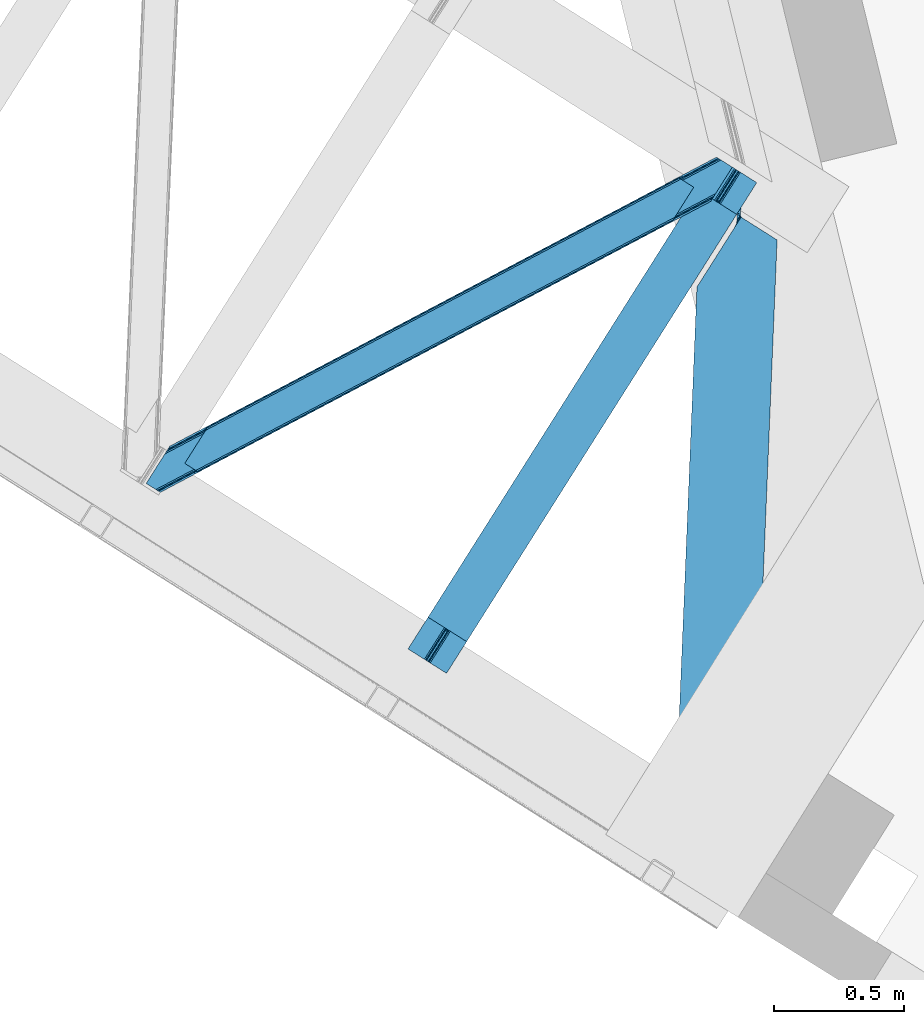
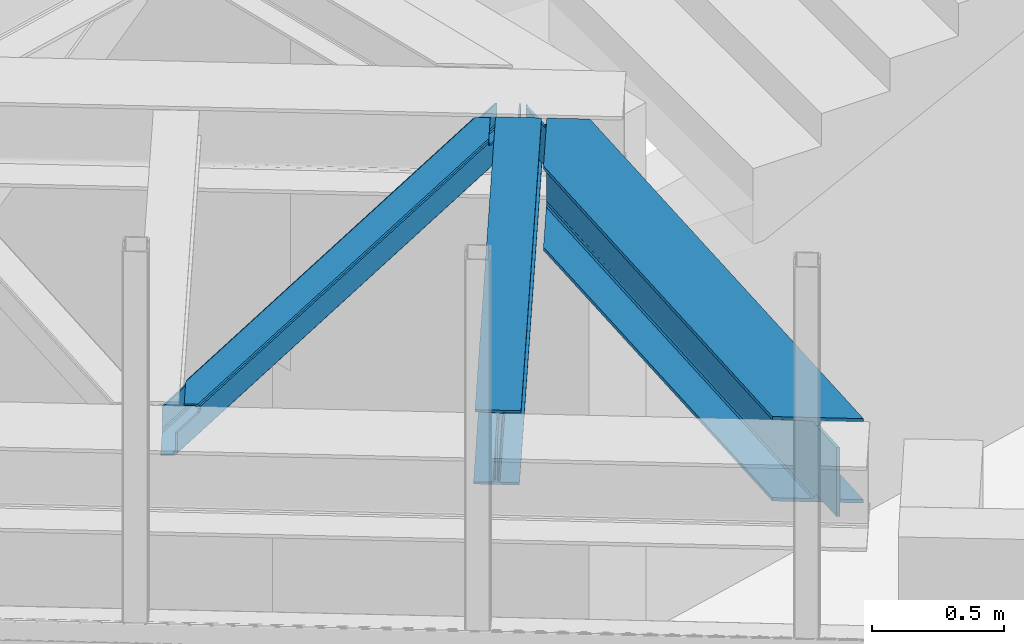
# One storey, part 50 of 67: 2 beams, 1 member.
"""IFC4 building model written with IfcOpenShell, lengths in millimetres."""

from ifc_helpers import new_model, entity, si_unit, converted_unit, derived_unit, direction, frame, origin, place, context, subcontext, project, spatial, triangles, type_object, element, save


model = new_model("IFC4")

# Units and contexts
model_context = context("Model", 3, precision=0.01, world=origin(), true_north=direction((6.12303176911189e-17, 1.0)))
plan_context = context("Plan", 3, precision=0.01, world=origin(), true_north=direction((6.12303176911189e-17, 1.0)))
body_context = subcontext(model_context, "Body", "Model", "MODEL_VIEW")
ifc_project = project(units=[si_unit("LENGTHUNIT", "METRE", prefix="MILLI"), si_unit("AREAUNIT", "SQUARE_METRE"), si_unit("VOLUMEUNIT", "CUBIC_METRE"), converted_unit("PLANEANGLEUNIT", "DEGREE", entity("IfcRatioMeasure", 0.0174532925199433), si_unit("PLANEANGLEUNIT", "RADIAN"), dimensions=[0, 0, 0, 0, 0, 0, 0]), si_unit("MASSUNIT", "GRAM", prefix="KILO"), derived_unit("MASSDENSITYUNIT", [(si_unit("MASSUNIT", "GRAM", prefix="KILO"), 1), (si_unit("LENGTHUNIT", "METRE"), -3)]), derived_unit("MOMENTOFINERTIAUNIT", [(si_unit("LENGTHUNIT", "METRE"), 4)]), si_unit("TIMEUNIT", "SECOND"), si_unit("FREQUENCYUNIT", "HERTZ"), si_unit("THERMODYNAMICTEMPERATUREUNIT", "DEGREE_CELSIUS"), derived_unit("THERMALTRANSMITTANCEUNIT", [(si_unit("MASSUNIT", "GRAM", prefix="KILO"), 1), (si_unit("THERMODYNAMICTEMPERATUREUNIT", "KELVIN"), -1), (si_unit("TIMEUNIT", "SECOND"), -3)]), derived_unit("VOLUMETRICFLOWRATEUNIT", [(si_unit("LENGTHUNIT", "METRE"), 3), (si_unit("TIMEUNIT", "SECOND"), -1)]), derived_unit("MASSFLOWRATEUNIT", [(si_unit("MASSUNIT", "GRAM", prefix="KILO"), 1), (si_unit("TIMEUNIT", "SECOND"), -1)]), derived_unit("ROTATIONALFREQUENCYUNIT", [(si_unit("TIMEUNIT", "SECOND"), -1)]), si_unit("ELECTRICCURRENTUNIT", "AMPERE"), si_unit("ELECTRICVOLTAGEUNIT", "VOLT"), si_unit("POWERUNIT", "WATT"), si_unit("FORCEUNIT", "NEWTON", prefix="KILO"), si_unit("ILLUMINANCEUNIT", "LUX"), si_unit("LUMINOUSFLUXUNIT", "LUMEN"), si_unit("LUMINOUSINTENSITYUNIT", "CANDELA"), derived_unit("USERDEFINED", [(si_unit("MASSUNIT", "GRAM", prefix="KILO"), -1), (si_unit("LENGTHUNIT", "METRE"), -2), (si_unit("TIMEUNIT", "SECOND"), 3), (si_unit("LUMINOUSFLUXUNIT", "LUMEN"), 1)]), derived_unit("LINEARVELOCITYUNIT", [(si_unit("LENGTHUNIT", "METRE"), 1), (si_unit("TIMEUNIT", "SECOND"), -1)]), si_unit("PRESSUREUNIT", "PASCAL"), derived_unit("USERDEFINED", [(si_unit("LENGTHUNIT", "METRE"), -2), (si_unit("MASSUNIT", "GRAM", prefix="KILO"), 1), (si_unit("TIMEUNIT", "SECOND"), -2)]), derived_unit("LINEARFORCEUNIT", [(si_unit("MASSUNIT", "GRAM", prefix="KILO"), 1), (si_unit("LENGTHUNIT", "METRE"), 1), (si_unit("TIMEUNIT", "SECOND"), -2), (si_unit("LENGTHUNIT", "METRE"), -1)]), derived_unit("PLANARFORCEUNIT", [(si_unit("MASSUNIT", "GRAM", prefix="KILO"), 1), (si_unit("LENGTHUNIT", "METRE"), 1), (si_unit("TIMEUNIT", "SECOND"), -2), (si_unit("LENGTHUNIT", "METRE"), -2)])], contexts=[model_context, plan_context])

# Site, building, storey
site_placement = place(None, origin())
site = spatial("IfcSite", under=ifc_project, at=site_placement, CompositionType="ELEMENT")
building_placement = place(site_placement, origin())
building = spatial("IfcBuilding", under=site, at=building_placement, CompositionType="ELEMENT")
storey_placement = place(building_placement, frame((0.0, 0.0, 19800.0)))
storey = spatial("IfcBuildingStorey", under=building, at=storey_placement, CompositionType="ELEMENT", Elevation=19800.0)

# Beams
beam_type_1 = type_object("IfcBeamType", PredefinedType="BEAM")
beam_1_placement = place(storey_placement, frame((-1267.76636695862, 13575.9713378906, 3863.99976196289)))
element("IfcBeam", 1, at=beam_1_placement, inside=storey, type_object=beam_type_1, ObjectType="Steel Beam", PredefinedType="BEAM", context=body_context, shape_type="Tessellation", body=[
    triangles([(1113.74242901802, 1855.23675842285, 232.99973144531), (1171.22194197178, 1818.90060424805, 232.99973144531), (134.557775115967, 179.105346679688, 232.99973144531), (77.078289413452, 215.441500854493, 232.99973144531), (1113.74242901802, 1855.23675842285, 244.001385498046), (77.078289413452, 215.441500854493, 244.001385498046), (1261.66156323999, 1761.72269897461, 244.001385498046), (225.001891136169, 121.928604125977, 244.001385498046), (1261.66156323999, 1761.72269897461, 232.99973144531), (225.001891136169, 121.928604125977, 232.99973144531), (1204.18659954071, 1798.06001586914, 232.99973144531), (167.522478103638, 158.264758300782, 232.99973144531), (1199.00899951458, 1801.33190917969, 231.783526611329), (1176.39499104023, 1815.62754821777, 231.783526611329), (1191.69133661985, 1805.95953369141, 223.123590087889), (1180.78569324017, 1812.85446166992, 228.313970947263), (1194.62281647921, 1804.10615844727, 228.313970947263), (1190.76869580746, 1806.54321899414, 219.000585937498), (1184.63980937004, 1810.41740112305, 219.000585937498), (1183.71717309952, 1811.00108642578, 223.123590087889), (157.958672332764, 164.310900878907, 228.313970947263), (162.344887161255, 161.536651611328, 231.783526611329), (144.121508216858, 173.06036682129, 228.313970947263), (139.730860519409, 175.832290649414, 231.783526611329), (154.104547119141, 166.747961425781, 219.000585937498), (155.027165222168, 166.164276123047, 223.123590087889), (147.975706100464, 170.622143554687, 219.000585937498), (147.053015327454, 171.206991577148, 223.123590087889), (147.982028388977, 170.400064086914, 217.00070800781), (1184.84340341091, 1810.50576782227, 217.00070800781), (1190.76235535145, 1806.76529846191, 217.00070800781), (153.900925827026, 166.659594726563, 217.00070800781), (1191.11113493443, 1807.31759033203, 214.791540527342), (1185.19218299389, 1811.05805969238, 214.791540527342), (1192.38168329, 1809.33258361816, 211.221990966795), (1186.46725051403, 1813.07421569824, 211.221990966795), (1194.28882523775, 1812.34867858887, 208.838415527342), (1188.37442879677, 1816.09031066895, 208.838415527342), (1196.54243041277, 1815.90776367188, 208.001257324217), (1190.62348301411, 1819.64823303223, 208.001257324217), (153.55218257904, 166.107302856446, 214.791540527342), (147.633212471008, 169.847772216797, 214.791540527342), (152.277042388916, 164.092309570313, 211.221990966795), (146.358217620849, 167.831616210937, 211.221990966795), (150.369964027405, 161.075051879883, 208.838415527342), (144.450993919372, 164.815521240234, 208.838415527342), (148.120828056335, 157.517129516602, 208.001257324217), (142.201930618286, 161.257598876953, 208.001257324217), (1267.74426928712, 1928.53809814453, 208.001257324217), (1261.82531823367, 1932.27856750488, 208.001257324217), (76.9144912719726, 44.8867950439453, 208.001257324217), (71.0000993728638, 48.6272644042965, 208.001257324217), (1261.82531823367, 1932.27856750488, 27.0006774902322), (71.0000993728638, 48.6272644042965, 27.0006774902322), (1267.74426928712, 1928.53809814453, 27.0006774902322), (76.9144912719726, 44.8867950439453, 27.0006774902322), (1253.4777905345, 1937.55615234375, 12.2178588867173), (1248.30474373698, 1940.82920837402, 10.9993286132813), (57.4749801635742, 57.1767425537109, 10.9993286132813), (62.6525711059569, 53.9060119628903, 12.2178588867173), (1257.86397470534, 1934.78190307617, 15.6874145507791), (67.0387859344482, 51.1317626953132, 15.6874145507791), (1260.8000060901, 1932.92969055176, 20.877795410157), (69.970220375061, 49.2783874511715, 20.877795410157), (1190.82522397041, 1977.16536254883, 10.9993286132813), (0.0, 93.5140594482418, 10.9993286132813), (1190.82522397041, 1977.16536254883, 0.0), (0.0, 93.5140594482418, 0.0), (1338.74436103106, 1883.65130310059, 0.0), (147.91916885376, 0.0, 0.0), (85.2665977478027, 39.6092102050789, 12.2178588867173), (80.8758047103881, 42.3822967529304, 15.6874145507791), (77.9443702697754, 44.2356719970703, 20.877795410157), (90.4396104812622, 36.3373168945309, 10.9993286132813), (147.91916885376, 0.0, 10.9993286132813), (1271.70561341867, 1926.03359985352, 15.6874145507791), (1276.09179787338, 1923.25935058594, 12.2178588867173), (1281.26939676404, 1919.98861999512, 10.9993286132813), (1338.74436103106, 1883.65130310059, 10.9993286132813), (1268.77413476575, 1927.88697509766, 20.877795410157)], [[1, 2, 3], [3, 4, 1], [5, 1, 4], [4, 6, 5], [7, 5, 8], [6, 8, 5], [9, 7, 10], [8, 10, 7], [11, 9, 10], [10, 12, 11], [11, 13, 14], [15, 16, 17], [13, 17, 16], [15, 18, 19], [7, 11, 5], [11, 7, 9], [2, 11, 14], [16, 15, 20], [19, 20, 15], [16, 14, 13], [2, 5, 11], [5, 2, 1], [21, 22, 23], [12, 8, 6], [10, 8, 12], [22, 12, 24], [25, 26, 27], [26, 21, 23], [23, 22, 24], [6, 3, 12], [3, 24, 12], [6, 4, 3], [23, 28, 26], [28, 27, 26], [19, 29, 27], [27, 20, 19], [19, 30, 29], [27, 28, 20], [16, 20, 23], [28, 23, 20], [14, 16, 23], [23, 24, 14], [2, 14, 3], [24, 3, 14], [25, 31, 18], [18, 26, 25], [18, 15, 26], [25, 32, 31], [15, 17, 26], [21, 26, 17], [17, 13, 22], [22, 21, 17], [13, 11, 12], [12, 22, 13], [31, 33, 34], [34, 30, 31], [18, 31, 30], [30, 19, 18], [33, 35, 34], [36, 34, 35], [35, 37, 38], [38, 36, 35], [37, 39, 38], [40, 38, 39], [41, 32, 42], [29, 42, 32], [32, 25, 27], [27, 29, 32], [43, 41, 42], [42, 44, 43], [45, 43, 46], [44, 46, 43], [47, 45, 46], [46, 48, 47], [49, 50, 39], [40, 39, 50], [47, 48, 51], [52, 51, 48], [36, 53, 54], [38, 53, 36], [50, 53, 40], [38, 40, 53], [30, 34, 42], [34, 36, 42], [44, 36, 54], [54, 46, 44], [48, 46, 54], [54, 52, 48], [44, 42, 36], [42, 29, 30], [55, 35, 56], [33, 41, 35], [37, 35, 55], [33, 31, 32], [55, 39, 37], [39, 55, 49], [56, 35, 43], [43, 35, 41], [32, 41, 33], [43, 45, 56], [47, 56, 45], [56, 47, 51], [57, 58, 59], [59, 60, 57], [61, 57, 62], [60, 62, 57], [63, 61, 62], [62, 64, 63], [53, 63, 54], [64, 54, 63], [58, 65, 66], [66, 59, 58], [65, 67, 66], [68, 66, 67], [67, 69, 68], [70, 68, 69], [71, 72, 60], [56, 64, 73], [72, 73, 62], [56, 51, 54], [74, 68, 70], [70, 75, 74], [74, 71, 59], [60, 72, 62], [64, 56, 54], [52, 54, 51], [64, 62, 73], [68, 74, 59], [60, 59, 71], [66, 68, 59], [76, 77, 57], [78, 69, 67], [79, 69, 78], [77, 78, 58], [55, 80, 63], [80, 76, 61], [49, 55, 53], [61, 76, 57], [67, 58, 78], [58, 57, 77], [67, 65, 58], [63, 53, 55], [53, 50, 49], [61, 63, 80], [80, 55, 73], [56, 73, 55], [76, 80, 73], [73, 72, 76], [77, 76, 71], [72, 71, 76], [78, 77, 71], [71, 74, 78], [79, 78, 75], [74, 75, 78], [69, 79, 70], [75, 70, 79]]),
])
beam_type_2 = type_object("IfcBeamType", PredefinedType="BEAM")
beam_2_placement = place(storey_placement, frame((-235.751834535599, 12925.2843109131, 3715.9994934082)))
element("IfcBeam", 2, at=beam_2_placement, inside=storey, type_object=beam_type_2, ObjectType="Steel Beam", PredefinedType="BEAM", context=body_context, shape_type="Tessellation", body=[
    triangles([(233.281526336074, 2423.1276763916, 356.001525878906), (244.678622616827, 2415.92462768555, 356.001525878906), (238.341486717761, 2545.92599487305, 356.001525878906), (250.747194671631, 2565.55502929687, 356.001525878906), (245.781376549602, 2403.50561828613, 362.41043701172), (244.023252917826, 2403.74630126953, 364.221954345703), (245.537573298812, 2402.36499023438, 367.000854492188), (242.53565749079, 2405.33225097656, 362.817388916017), (244.82996353358, 2406.62286987305, 359.222259521484), (241.500046648085, 2406.43916015625, 361.83837890625), (238.207450908422, 2409.10643920898, 361.001220703125), (232.385556542873, 2414.48983154297, 359.222259521484), (231.81794237718, 2413.14689025879, 361.001220703125), (244.56884098202, 2411.01329956055, 356.838684082031), (232.990733709186, 2418.33145751953, 356.838684082031), (248.213948589563, 2400.67439575195, 367.000854492188), (231.194143527746, 2398.01176757813, 361.001220703125), (245.848223850131, 2402.17081604004, 367.79150390625), (229.080534236133, 2380.1116973877, 364.221954345703), (226.37978554666, 2371.37618408203, 367.79150390625), (246.55568203032, 2401.72316894531, 372.000549316406), (224.501758146286, 2367.80779724121, 369.407684326172), (221.500491258502, 2362.09186706543, 372.000549316406), (230.523896920681, 2389.07626647949, 361.83837890625), (230.180002690852, 2386.93221130371, 362.408111572266), (265.525510007143, 2389.72971496582, 376.000305175781), (257.313895046711, 2394.92125854492, 374.325988769531), (246.55568203032, 2401.72316894531, 392.001654052736), (250.749615490437, 2399.07100524902, 369.042590332032), (384.774951267242, 2314.34245605469, 392.001654052736), (384.774951267242, 2314.34245605469, 376.000305175781), (292.630248641968, 77.4278320312496, 392.001654052736), (292.630248641968, 77.4278320312496, 376.000305175781), (173.385328817368, 152.816253662109, 376.000305175781), (77.0741108894348, 2133.64185791016, 392.001654052736), (0.0, 262.429330444336, 392.001654052736), (216.970907637477, 2354.92835083008, 374.325988769531), (207.956919550896, 2340.67108154297, 376.000305175781), (77.0741108894348, 2133.64185791016, 376.000305175781), (119.244928908348, 187.040908813477, 376.000305175781), (0.0, 262.429330444336, 376.000305175781), (158.208139300346, 162.40869140625, 369.556512451174), (165.173679792881, 158.008959960938, 374.325988769531), (134.422118425369, 177.448471069336, 369.556512451174), (127.461097097397, 181.849365234375, 374.325988769531), (152.011397266388, 166.325894165038, 356.001525878906), (153.556270265579, 165.350372314453, 362.419738769531), (140.61885137558, 173.531268310548, 356.001525878906), (139.073923873901, 174.50795288086, 362.419738769531), (133.766217327118, 7.20304870605469, 356.001525878906), (145.163350510597, 0.0, 356.001525878906), (133.856409859657, 7.14723815917932, 354.001647949219), (238.437992171198, 2546.08063659668, 354.001647949219), (250.747194671631, 2565.55502929687, 354.001647949219), (145.07314889431, 0.0558105468753638, 354.001647949219), (250.747194671631, 2565.55502929687, 179.000701904297), (238.437992171198, 2546.08063659668, 179.000701904297), (244.730604931712, 2419.42325134277, 179.000701904297), (232.416850054264, 2399.94769592285, 179.000701904297), (244.381695905328, 2410.99585876465, 178.163543701172), (232.072493688762, 2391.52146606445, 178.163543701172), (244.088522484899, 2403.85210876465, 175.777642822268), (231.77476760745, 2384.37655334473, 175.777642822268), (243.892482148111, 2399.07914428711, 172.210418701172), (231.578761618584, 2379.60358886719, 172.210418701172), (243.822449858487, 2397.40250244141, 168.001373291016), (231.508694413304, 2377.92694702148, 168.001373291016), (133.856409859657, 7.14723815917932, 38.0000061035171), (231.508694413304, 2377.92694702148, 38.0000061035171), (145.07314889431, 0.0558105468753638, 38.0000061035171), (243.822449858487, 2397.40250244141, 38.0000061035171), (145.163350510597, 0.0, 36.0001281738296), (133.766217327118, 7.20304870605469, 36.0001281738296), (152.011397266388, 166.325894165038, 36.0001281738296), (140.61885137558, 173.531268310548, 36.0001281738296), (229.720073233545, 2375.09223632813, 29.5819152832046), (139.073923873901, 174.50795288086, 29.5819152832046), (224.613497328758, 2367.01598510742, 22.4451416015654), (134.422118425369, 177.448471069336, 22.4451416015654), (216.970907637477, 2354.92835083008, 17.6756652832046), (127.461097097397, 181.849365234375, 17.6756652832046), (207.956919550896, 2340.67108154297, 16.0013488769546), (119.244928908348, 187.040908813477, 16.0013488769546), (0.0, 262.429330444336, 16.0013488769546), (77.0741108894348, 2133.64185791016, 16.0013488769546), (77.0741108894348, 2133.64185791016, 0.0), (0.0, 262.429330444336, 0.0), (246.55568203032, 2401.72316894531, 0.0), (246.55568203032, 2401.72316894531, 25.0007995605483), (245.615590202808, 2400.23837585449, 29.5819152832046), (246.704236507416, 2401.95920104981, 27.4587890625007), (248.213948589563, 2400.67439575195, 25.0007995605483), (257.313895046711, 2394.92125854492, 17.6756652832046), (250.749615490437, 2399.07100524902, 22.9590637207039), (158.208139300346, 162.40869140625, 22.4451416015654), (153.556270265579, 165.350372314453, 29.5819152832046), (165.173679792881, 158.008959960938, 17.6756652832046), (265.525510007143, 2389.72971496582, 16.0013488769546), (173.385328817368, 152.816253662109, 16.0013488769546), (292.630248641968, 77.4278320312496, 0.0), (292.630248641968, 77.4278320312496, 16.0013488769546), (384.774951267242, 2314.34245605469, 0.0), (384.774951267242, 2314.34245605469, 16.0013488769546)], [[1, 2, 3], [4, 3, 2], [5, 6, 7], [5, 8, 6], [9, 10, 8], [11, 9, 12], [12, 13, 11], [11, 10, 9], [14, 2, 15], [1, 15, 2], [9, 14, 12], [15, 12, 14], [8, 5, 9], [7, 16, 5], [11, 13, 17], [18, 7, 19], [19, 20, 18], [21, 20, 22], [20, 21, 18], [22, 23, 21], [7, 6, 19], [6, 8, 24], [8, 10, 24], [6, 25, 19], [25, 6, 24], [10, 11, 17], [17, 24, 10], [26, 27, 28], [27, 29, 21], [30, 26, 28], [26, 30, 31], [21, 28, 27], [16, 18, 21], [7, 18, 16], [16, 21, 29], [31, 30, 32], [32, 33, 31], [33, 34, 31], [26, 31, 34], [35, 32, 30], [35, 36, 32], [30, 28, 35], [21, 23, 28], [28, 37, 38], [37, 28, 23], [38, 35, 28], [35, 38, 39], [40, 41, 39], [39, 38, 40], [35, 39, 36], [41, 36, 39], [42, 43, 44], [34, 32, 36], [33, 32, 34], [43, 34, 45], [46, 47, 48], [47, 42, 49], [44, 43, 45], [36, 40, 34], [40, 45, 34], [36, 41, 40], [44, 49, 42], [49, 48, 47], [50, 51, 46], [46, 48, 50], [44, 45, 37], [37, 23, 44], [49, 44, 22], [22, 20, 49], [20, 19, 49], [52, 15, 1], [1, 53, 52], [1, 3, 53], [52, 24, 17], [17, 12, 52], [24, 52, 48], [48, 25, 24], [17, 13, 12], [12, 15, 52], [48, 49, 25], [52, 50, 48], [19, 25, 49], [23, 22, 44], [38, 37, 45], [45, 40, 38], [27, 43, 42], [42, 5, 16], [5, 42, 47], [16, 29, 42], [47, 14, 9], [46, 54, 2], [2, 47, 46], [2, 14, 47], [54, 4, 2], [9, 5, 47], [54, 46, 55], [51, 55, 46], [42, 29, 27], [27, 26, 43], [34, 43, 26], [54, 56, 53], [4, 54, 53], [57, 53, 56], [53, 3, 4], [58, 59, 57], [57, 56, 58], [58, 60, 59], [61, 59, 60], [60, 62, 61], [63, 61, 62], [62, 64, 63], [65, 63, 64], [64, 66, 65], [67, 65, 66], [53, 63, 65], [61, 63, 53], [53, 59, 61], [59, 53, 57], [67, 68, 52], [68, 67, 69], [65, 52, 53], [52, 65, 67], [62, 54, 64], [58, 54, 60], [58, 56, 54], [62, 60, 54], [55, 64, 54], [66, 55, 70], [55, 66, 64], [70, 71, 66], [70, 55, 68], [55, 51, 52], [72, 70, 73], [68, 55, 52], [50, 52, 51], [68, 73, 70], [72, 73, 74], [75, 74, 73], [75, 69, 76], [76, 77, 75], [69, 75, 68], [73, 68, 75], [76, 78, 77], [79, 77, 78], [78, 80, 79], [81, 79, 80], [80, 82, 81], [83, 81, 82], [84, 83, 85], [82, 85, 83], [85, 86, 84], [87, 84, 86], [88, 89, 76], [76, 90, 71], [67, 69, 71], [67, 71, 66], [89, 91, 90], [89, 90, 76], [82, 88, 80], [78, 88, 76], [69, 76, 71], [78, 80, 88], [82, 86, 88], [86, 82, 85], [92, 89, 91], [93, 94, 95], [92, 91, 90], [96, 95, 94], [94, 92, 96], [71, 70, 74], [74, 90, 71], [74, 96, 90], [70, 72, 74], [90, 96, 92], [95, 97, 93], [98, 93, 97], [97, 99, 98], [99, 97, 81], [96, 77, 95], [97, 95, 79], [96, 74, 75], [100, 99, 87], [99, 100, 101], [83, 99, 81], [79, 95, 77], [75, 77, 96], [79, 81, 97], [83, 87, 99], [87, 83, 84], [93, 98, 88], [102, 98, 103], [98, 102, 88], [94, 88, 89], [88, 94, 93], [89, 92, 94], [100, 86, 102], [86, 100, 87], [88, 102, 86], [99, 101, 103], [103, 98, 99], [102, 103, 100], [101, 100, 103]]),
])

# Member
member_type = type_object("IfcMemberType", PredefinedType="BRACE")
member_placement = place(storey_placement, frame((-2272.77551651001, 14270.5231292725, 3964.00063476562)))
element("IfcMember", 3, at=member_placement, inside=storey, type_object=member_type, ObjectType="Steel Horizontal Brace", PredefinedType="BRACE", context=body_context, shape_type="Tessellation", body=[
    triangles([(2166.61486344337, 1116.62719116211, 113.0000793457), (2173.80174307823, 1127.99161376953, 113.0000793457), (2044.4205051899, 1059.94925537109, 113.0000793457), (2036.90270462036, 1048.05812072754, 113.0000793457), (2029.42218375206, 1044.1037109375, 113.837237548825), (2032.01686549187, 1053.39151611328, 115.49992675781), (2030.77495365143, 1052.79155273437, 116.285925292967), (2036.94003882408, 1055.99484558105, 113.837237548825), (2026.93752436638, 1051.31141052246, 119.790362548825), (2018.84619412422, 1038.51219177246, 119.790362548825), (2023.08254528046, 1040.75158996582, 116.220812988278), (2028.56100811958, 1051.72068786621, 117.688165283202), (2026.56859703064, 1052.01950683594, 122.19719238281), (2017.54004201889, 1037.82153625488, 122.499499511716), (2017.42678585053, 1037.83432617187, 123.999407958981), (2027.24235677719, 1053.36012268066, 123.999407958981), (200.000582885742, 78.5370666503895, 129.196765136716), (201.301375579834, 77.717349243163, 122.499499511716), (2018.78793096542, 1039.9888458252, 129.196765136716), (2022.86099267006, 1046.4326385498, 134.873162841795), (196.304878234863, 80.8741333007802, 134.873162841795), (2028.95898528099, 1056.07856140137, 138.668280029295), (190.775273895264, 84.3727569580078, 138.668280029295), (2036.15227804184, 1067.45577392578, 139.998431396481), (184.250090789795, 88.4980865478501, 139.998431396481), (193.497927474975, 81.5101409912095, 114.86740722656), (194.136696624756, 82.2473052978512, 118.999713134763), (192.620655441284, 83.2042236328125, 121.887908935547), (189.485236358642, 85.1866607666016, 127.873590087889), (2030.37881140709, 1058.32493591309, 127.873590087889), (2043.67013311386, 1079.34690856934, 132.998858642575), (2036.47684035301, 1067.96969604492, 131.666381835938), (177.425943374634, 92.8094512939442, 132.998858642575), (183.951126480103, 88.6841217041001, 131.666381835938), (201.301375579834, 77.717349243163, 118.999713134763), (148.082821655273, 111.360644531249, 139.998431396481), (148.082821655273, 111.360644531249, 132.998858642575), (2101.84745049477, 1171.37268676758, 139.998431396481), (2101.84745049477, 1171.37268676758, 132.998858642575), (2059.13757562637, 1198.37336425781, 139.998431396481), (220.991888809204, 226.688488769531, 139.998431396481), (2065.9571993351, 1194.06083679199, 132.998858642575), (213.474033737183, 214.797354125976, 132.998858642575), (226.76537361145, 235.819326782226, 127.873590087889), (228.185199737549, 238.066864013672, 138.668280029295), (220.667344665527, 226.17456665039, 131.666381835938), (234.283228683472, 247.711624145508, 134.873162841795), (229.901810073852, 240.784140014648, 123.999407958981), (238.35623588562, 254.155416870117, 129.196765136716), (239.717344665527, 256.309936523438, 123.999407958981), (2043.38265066147, 1208.33322143555, 129.196765136716), (2042.08625450134, 1209.1541015625, 122.499499511716), (239.604124832153, 256.322726440429, 122.499499511716), (2052.6124288559, 1202.49985656738, 138.668280029295), (2047.07826447487, 1205.99615478516, 134.873162841795), (2053.90241189003, 1201.68479003906, 127.873590087889), (2059.43205256462, 1198.18732910156, 131.666381835938), (2050.76254177094, 1203.66722717285, 121.887908935547), (2049.25095162392, 1204.62414550781, 118.999713134763), (2042.08625450134, 1209.1541015625, 118.999713134763), (230.575606155395, 242.124755859375, 122.19719238281), (2049.88982977867, 1205.36130981445, 114.86740722656), (228.587500762939, 242.424737548827, 117.690490722656), (226.52614402771, 241.474795532225, 116.220812988278), (230.206587982178, 242.832852172851, 119.790362548825), (225.127246856689, 240.752746582031, 115.49992675781), (238.297954559326, 255.632070922851, 119.790362548825), (234.061585235596, 253.392672729491, 116.220812988278), (227.722001266479, 250.040551757811, 113.837237548825), (220.204146194458, 238.149417114257, 113.837237548825), (220.241498565674, 246.087304687499, 113.0000793457), (212.723643493652, 234.195007324219, 113.0000793457), (199.660342025757, 76.8499603271484, 115.109252929688), (198.014802932739, 75.9802459716793, 111.22111816406), (190.089123916626, 71.7909667968743, 108.000384521481), (194.054288864136, 73.8861877441395, 109.609588623047), (187.230141448974, 78.1975524902336, 109.609588623047), (183.269482040405, 76.1034942626939, 108.000384521481), (191.195161056518, 80.2927734374989, 111.22111816406), (2045.36841244698, 1210.89004211426, 111.22111816406), (2043.72734255791, 1210.02265319824, 115.109252929688), (2052.1880361557, 1206.57751464844, 111.22111816406), (2056.15312843323, 1208.6727355957, 109.609588623047), (2049.3335047245, 1212.98526306152, 109.609588623047), (2060.11818437576, 1210.7691192627, 108.000384521481), (2053.2940369606, 1215.08048400879, 108.000384521481), (54.2830238342285, 0.0, 108.000384521481), (47.4635272979735, 4.31252746581958, 108.000384521481), (2166.61486344337, 1116.62719116211, 17.4989318847656), (54.2830238342285, 0.0, 17.4989318847656), (2032.0435353756, 1053.34151916504, 115.49992675781), (2174.14860599041, 1128.49274597168, 24.4985046386719), (191.196323776245, 80.2881225585934, 111.22111816406), (2173.68541660309, 1128.21253051758, 113.0000793457), (2044.44708423615, 1059.89925842285, 113.0000793457), (2174.16452071667, 1128.46716613769, 112.135015869138), (2036.96659970284, 1055.94484863281, 113.837237548825), (47.4478305816651, 4.3381072998036, 24.4985046386719), (183.2703540802, 76.1000061035156, 108.000384521481), (187.235664367676, 78.1940643310536, 109.609588623047), (47.4633819580076, 4.31369018554688, 108.000384521481), (193.499235534668, 81.5043273925767, 114.86740722656), (2185.41397941113, 1146.35793457031, 0.0), (2178.22067756653, 1134.9807220459, 1.33247680663771), (37.2317390441895, 10.7807373046871, 0.0), (43.7569221496583, 6.65540771484302, 1.33247680663771), (2172.12263953686, 1125.33479919434, 5.12526855468604), (49.2910320281981, 3.15910949706995, 5.12526855468604), (2168.04959599972, 1118.89100646973, 10.8016662597656), (52.9867366790772, 0.822042846679324, 10.8016662597656), (2174.1327185154, 1128.51832580566, 24.4985046386719), (2175.56744198799, 1130.78330383301, 17.8035644531228), (46.1670948028564, 5.13457031249891, 17.8035644531228), (47.4635272979735, 4.31252746581958, 24.4985046386719), (2179.64049460888, 1137.22709655762, 12.1248413085923), (42.4668846130371, 7.47047424316406, 12.1248413085923), (2185.7385235548, 1146.87185668945, 8.33204956054396), (36.9372802734374, 10.9679351806626, 8.33204956054396), (2192.93179814816, 1158.25023193359, 6.99957275390625), (30.4120971679686, 15.0932647705067, 6.99957275390625), (2249.93033573627, 1248.41333312988, 6.99957275390625), (2249.93033573627, 1248.41333312988, 0.0), (2174.1327185154, 1128.51832580566, 112.135015869138), (2195.92426629066, 1282.55892333984, 108.000384521481), (2189.1001188755, 1286.87028808594, 108.000384521481), (0.0, 34.3199981689449, 6.99957275390625), (0.0, 34.3199981689449, 0.0), (90.5293579101563, 177.517071533202, 113.0000793457), (83.0115028381347, 165.625936889648, 113.0000793457), (2189.1001188755, 1286.87028808594, 17.4989318847656), (90.5293579101563, 177.517071533202, 17.4989318847656), (2206.15144000053, 1276.08955078125, 0.0), (71.730214691162, 147.786328124999, 0.0), (2190.40098423958, 1286.05057067871, 10.8016662597656), (89.0945617675779, 175.253256225586, 10.8016662597656), (2194.09663438797, 1283.71350402832, 5.12526855468604), (85.0214092254637, 168.809463500977, 5.12526855468604), (2199.62629323006, 1280.21488037109, 1.33247680663771), (78.9233802795411, 159.163540649413, 1.33247680663771), (2200.91626263857, 1279.4009765625, 12.1248413085923), (2212.97554653883, 1271.77818603516, 6.99957275390625), (2206.45043610334, 1275.903515625, 8.33204956054396), (2195.92426629066, 1282.55892333984, 24.4985046386719), (2197.2206079483, 1281.73804321289, 17.8035644531228), (83.0115028381347, 165.625936889648, 24.4985046386719), (81.5767066955564, 163.360958862304, 17.8035644531228), (77.503699493408, 156.917166137695, 12.1248413085923), (64.2123596191404, 135.894030761718, 6.99957275390625), (71.4056705474854, 147.272406005859, 8.33204956054396)], [[1, 2, 3], [3, 4, 1], [5, 6, 7], [5, 8, 6], [9, 10, 11], [11, 7, 12], [13, 14, 10], [13, 15, 14], [10, 9, 13], [13, 16, 15], [11, 12, 9], [7, 11, 5], [3, 8, 4], [5, 4, 8], [15, 17, 18], [18, 14, 15], [15, 19, 17], [19, 20, 21], [21, 17, 19], [20, 22, 23], [23, 21, 20], [22, 24, 25], [25, 23, 22], [26, 9, 12], [7, 6, 26], [26, 12, 7], [9, 26, 27], [27, 13, 9], [27, 28, 13], [29, 30, 16], [16, 28, 29], [16, 13, 28], [31, 32, 33], [34, 33, 32], [32, 30, 34], [29, 34, 30], [21, 29, 23], [28, 17, 18], [18, 35, 27], [27, 28, 18], [29, 17, 28], [21, 17, 29], [34, 25, 23], [23, 29, 34], [34, 33, 25], [33, 36, 25], [37, 36, 33], [32, 22, 30], [38, 31, 39], [31, 38, 24], [32, 24, 22], [32, 31, 24], [20, 16, 30], [22, 20, 30], [16, 20, 19], [15, 16, 19], [24, 40, 41], [24, 38, 40], [41, 25, 24], [36, 25, 41], [42, 31, 43], [31, 42, 39], [33, 43, 31], [37, 43, 33], [44, 45, 46], [47, 48, 49], [44, 47, 45], [49, 48, 50], [47, 44, 48], [46, 45, 41], [36, 43, 41], [37, 43, 36], [43, 46, 41], [50, 51, 52], [52, 53, 50], [40, 54, 45], [45, 41, 40], [54, 55, 47], [47, 45, 54], [55, 51, 49], [49, 47, 55], [50, 49, 51], [56, 54, 55], [39, 38, 42], [38, 40, 42], [54, 57, 40], [56, 57, 54], [57, 42, 40], [51, 58, 56], [55, 51, 56], [58, 51, 52], [52, 59, 58], [52, 60, 59], [56, 44, 48], [48, 58, 56], [48, 61, 58], [62, 63, 64], [62, 65, 63], [64, 66, 62], [65, 62, 59], [59, 61, 65], [59, 58, 61], [56, 57, 44], [46, 44, 57], [57, 42, 46], [43, 46, 42], [61, 53, 67], [61, 50, 53], [67, 65, 61], [65, 67, 68], [68, 64, 63], [69, 66, 64], [69, 70, 66], [69, 71, 70], [72, 70, 71], [64, 68, 69], [68, 63, 65], [61, 48, 50], [27, 26, 73], [73, 35, 27], [74, 73, 26], [75, 76, 77], [77, 78, 75], [76, 74, 79], [79, 77, 76], [26, 79, 74], [80, 81, 62], [59, 62, 81], [81, 60, 59], [62, 82, 80], [82, 83, 84], [84, 80, 82], [83, 85, 86], [86, 84, 83], [75, 78, 87], [88, 87, 78], [11, 74, 89], [11, 10, 74], [14, 74, 10], [35, 73, 14], [35, 14, 18], [5, 11, 89], [89, 1, 4], [4, 5, 89], [90, 89, 74], [74, 14, 73], [74, 76, 90], [75, 90, 76], [90, 75, 87], [91, 92, 93], [94, 92, 95], [94, 96, 92], [91, 97, 92], [97, 95, 92], [93, 92, 98], [98, 99, 100], [98, 101, 99], [100, 93, 98], [93, 102, 91], [103, 104, 105], [106, 105, 104], [104, 107, 106], [108, 106, 107], [107, 109, 108], [110, 108, 109], [109, 89, 110], [90, 110, 89], [111, 112, 113], [113, 114, 111], [112, 115, 116], [116, 113, 112], [115, 117, 118], [118, 116, 115], [117, 119, 120], [120, 118, 117], [115, 107, 104], [115, 104, 117], [119, 117, 103], [112, 107, 115], [121, 119, 122], [103, 122, 119], [117, 104, 103], [109, 107, 112], [1, 89, 111], [111, 123, 1], [2, 1, 123], [109, 112, 89], [112, 111, 89], [124, 125, 85], [86, 85, 125], [110, 116, 108], [114, 90, 87], [87, 88, 114], [114, 113, 90], [113, 110, 90], [116, 110, 113], [106, 108, 116], [120, 105, 118], [116, 118, 106], [120, 126, 127], [118, 105, 106], [120, 127, 105], [72, 71, 128], [128, 129, 72], [80, 130, 131], [84, 130, 80], [125, 130, 86], [84, 86, 130], [60, 81, 53], [81, 80, 53], [52, 60, 53], [68, 80, 131], [131, 69, 68], [71, 69, 131], [131, 128, 71], [68, 67, 80], [67, 53, 80], [132, 103, 133], [103, 132, 122], [105, 133, 103], [127, 133, 105], [130, 134, 131], [135, 131, 134], [134, 136, 135], [137, 135, 136], [136, 138, 137], [139, 137, 138], [138, 132, 139], [133, 139, 132], [140, 138, 136], [121, 122, 141], [122, 132, 141], [138, 142, 132], [140, 142, 138], [142, 141, 132], [130, 143, 144], [134, 140, 136], [140, 134, 144], [134, 130, 144], [125, 143, 130], [125, 124, 143], [143, 82, 145], [83, 82, 143], [82, 62, 66], [143, 85, 83], [85, 143, 124], [145, 82, 66], [66, 70, 145], [72, 145, 70], [145, 72, 129], [137, 146, 147], [145, 131, 128], [128, 129, 145], [145, 146, 131], [146, 135, 131], [146, 137, 135], [139, 137, 147], [148, 133, 149], [147, 149, 139], [148, 126, 127], [149, 133, 139], [148, 127, 133], [119, 141, 148], [119, 121, 141], [148, 120, 119], [126, 120, 148], [141, 142, 149], [149, 148, 141], [142, 140, 147], [147, 149, 142], [140, 144, 146], [146, 147, 140], [144, 143, 145], [145, 146, 144]]),
])

save(model, "model.ifc")
